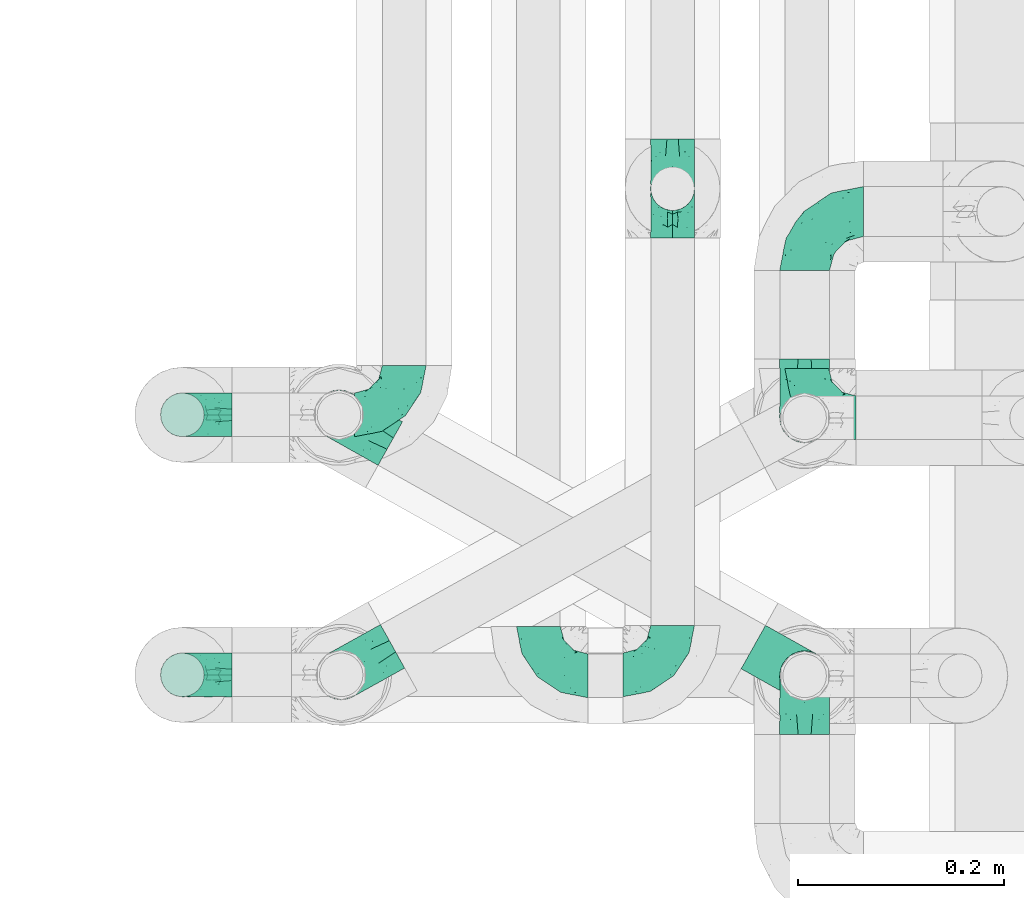
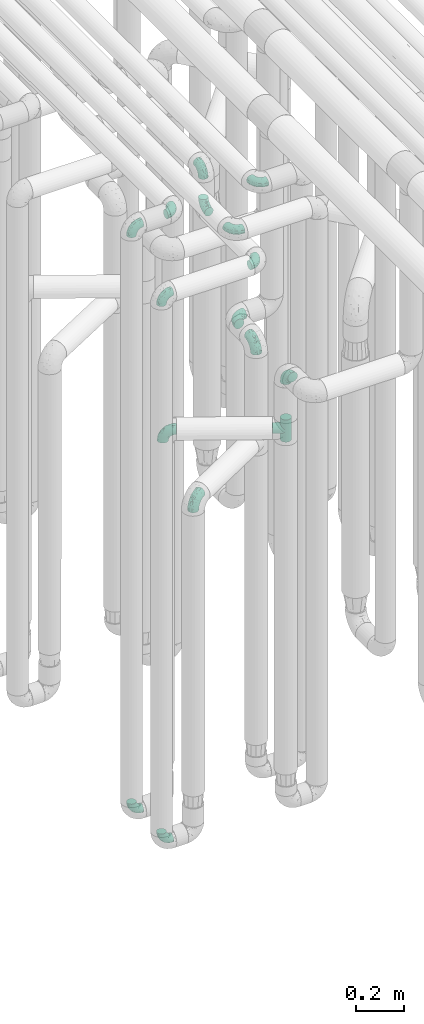
# One storey, part 598 of 824: 16 flow fittings.
"""IFC2X3 building model written with IfcOpenShell, lengths in millimetres."""

from ifc_helpers import new_model, entity, si_unit, converted_unit, derived_unit, direction, frame, origin, place, context, subcontext, project, spatial, faceted_brep, source, transform, mapped, material, type_object, type_shapes, element, save


model = new_model("IFC2X3")

# Units and contexts
model_context = context("Model", 3, precision=0.01, world=origin(), true_north=direction((6.12303176911189e-17, 1.0)))
body_context = subcontext(model_context, "Body", "Model", "MODEL_VIEW")
ifc_project = project(units=[si_unit("LENGTHUNIT", "METRE", prefix="MILLI"), si_unit("AREAUNIT", "SQUARE_METRE"), si_unit("VOLUMEUNIT", "CUBIC_METRE"), converted_unit("PLANEANGLEUNIT", "DEGREE", entity("IfcRatioMeasure", 0.0174532925199433), si_unit("PLANEANGLEUNIT", "RADIAN"), dimensions=[0, 0, 0, 0, 0, 0, 0]), si_unit("MASSUNIT", "GRAM", prefix="KILO"), derived_unit("MASSDENSITYUNIT", [(si_unit("MASSUNIT", "GRAM", prefix="KILO"), 1), (si_unit("LENGTHUNIT", "METRE"), -3)]), derived_unit("MOMENTOFINERTIAUNIT", [(si_unit("LENGTHUNIT", "METRE"), 4)]), si_unit("TIMEUNIT", "SECOND"), si_unit("FREQUENCYUNIT", "HERTZ"), si_unit("THERMODYNAMICTEMPERATUREUNIT", "DEGREE_CELSIUS"), derived_unit("THERMALTRANSMITTANCEUNIT", [(si_unit("MASSUNIT", "GRAM", prefix="KILO"), 1), (si_unit("THERMODYNAMICTEMPERATUREUNIT", "KELVIN"), -1), (si_unit("TIMEUNIT", "SECOND"), -3)]), derived_unit("VOLUMETRICFLOWRATEUNIT", [(si_unit("LENGTHUNIT", "METRE"), 3), (si_unit("TIMEUNIT", "SECOND"), -1)]), derived_unit("MASSFLOWRATEUNIT", [(si_unit("MASSUNIT", "GRAM", prefix="KILO"), 1), (si_unit("TIMEUNIT", "SECOND"), -1)]), derived_unit("ROTATIONALFREQUENCYUNIT", [(si_unit("TIMEUNIT", "SECOND"), -1)]), si_unit("ELECTRICCURRENTUNIT", "AMPERE"), si_unit("ELECTRICVOLTAGEUNIT", "VOLT"), si_unit("POWERUNIT", "WATT"), si_unit("FORCEUNIT", "NEWTON", prefix="KILO"), si_unit("ILLUMINANCEUNIT", "LUX"), si_unit("LUMINOUSFLUXUNIT", "LUMEN"), si_unit("LUMINOUSINTENSITYUNIT", "CANDELA"), derived_unit("USERDEFINED", [(si_unit("MASSUNIT", "GRAM", prefix="KILO"), -1), (si_unit("LENGTHUNIT", "METRE"), -2), (si_unit("TIMEUNIT", "SECOND"), 3), (si_unit("LUMINOUSFLUXUNIT", "LUMEN"), 1)]), derived_unit("LINEARVELOCITYUNIT", [(si_unit("LENGTHUNIT", "METRE"), 1), (si_unit("TIMEUNIT", "SECOND"), -1)]), si_unit("PRESSUREUNIT", "PASCAL"), derived_unit("USERDEFINED", [(si_unit("LENGTHUNIT", "METRE"), -2), (si_unit("MASSUNIT", "GRAM", prefix="KILO"), 1), (si_unit("TIMEUNIT", "SECOND"), -2)]), derived_unit("LINEARFORCEUNIT", [(si_unit("MASSUNIT", "GRAM", prefix="KILO"), 1), (si_unit("LENGTHUNIT", "METRE"), 1), (si_unit("TIMEUNIT", "SECOND"), -2), (si_unit("LENGTHUNIT", "METRE"), -1)]), derived_unit("PLANARFORCEUNIT", [(si_unit("MASSUNIT", "GRAM", prefix="KILO"), 1), (si_unit("LENGTHUNIT", "METRE"), 1), (si_unit("TIMEUNIT", "SECOND"), -2), (si_unit("LENGTHUNIT", "METRE"), -2)])], contexts=[model_context])

# Site, building, storey
site_placement = place(None, origin())
site = spatial("IfcSite", under=ifc_project, at=site_placement, CompositionType="ELEMENT")
building_placement = place(site_placement, origin())
building = spatial("IfcBuilding", under=site, at=building_placement, CompositionType="ELEMENT")
storey_placement = place(building_placement, frame((0.0, 0.0, 28200.0)))
storey = spatial("IfcBuildingStorey", under=building, at=storey_placement, CompositionType="ELEMENT", Elevation=28200.0)

# Flow fittings
ifc_material = material()
pipe_fitting_type_1 = type_object("IfcPipeFittingType", PredefinedType="NOTDEFINED", material=ifc_material)
shared_shape_1 = source(origin(), body_context, "Body", "Brep", [
    faceted_brep([(-57.0, 12.07, -20.91), (-57.0, 6.25, -23.33), (-57.0, 0.0, -24.15), (-57.0, -6.25, -23.33), (-57.0, -12.08, -20.91), (-57.0, -17.08, -17.08), (-57.0, -20.91, -12.08), (-57.0, -23.33, -6.25), (-57.0, -24.15, 0.0), (-57.0, -23.33, 6.25), (-57.0, -20.91, 12.07), (-57.0, -17.08, 17.08), (-57.0, -12.08, 20.91), (-57.0, -6.25, 23.33), (-57.0, 0.0, 24.15), (-57.0, 6.25, 23.33), (-57.0, 12.07, 20.91), (-57.0, 17.08, 17.08), (-57.0, 20.91, 12.07), (-57.0, 23.33, 6.25), (-57.0, 24.15, 0.0), (-57.0, 23.33, -6.25), (-57.0, 20.91, -12.08), (-57.0, 17.08, -17.08), (0.0, 57.0, -24.15), (-6.25, 57.0, -23.33), (-12.07, 57.0, -20.91), (-17.08, 57.0, -17.08), (-20.91, 57.0, -12.08), (-23.33, 57.0, -6.25), (-24.15, 57.0, 0.0), (-23.33, 57.0, 6.25), (-20.91, 57.0, 12.07), (-17.08, 57.0, 17.08), (-12.07, 57.0, 20.91), (-6.25, 57.0, 23.33), (0.0, 57.0, 24.15), (6.25, 57.0, 23.33), (12.08, 57.0, 20.91), (17.08, 57.0, 17.08), (20.91, 57.0, 12.07), (23.33, 57.0, 6.25), (24.15, 57.0, 0.0), (23.33, 57.0, -6.25), (20.91, 57.0, -12.08), (17.08, 57.0, -17.08), (12.08, 57.0, -20.91), (6.25, 57.0, -23.33), (14.9, 21.14, 6.17), (13.61, 24.64, 12.48), (6.23, 8.95, 8.98), (-41.47, -21.06, 0.0), (-41.92, -18.38, 13.72), (-24.64, -13.61, 12.48), (-37.37, -13.24, 18.15), (-6.8, -4.93, 8.18), (-21.76, -15.19, 6.22), (-12.78, -9.18, 0.0), (-37.73, -20.51, 7.75), (-7.38, 7.38, 20.24), (-23.37, -4.26, 20.42), (-11.9, -3.19, 15.86), (-42.14, -8.7, 21.82), (13.24, 37.37, 18.15), (9.33, 23.53, 16.85), (4.26, 23.37, 20.42), (2.77, 10.92, 15.55), (-29.46, 0.91, 23.52), (-44.13, 20.56, 15.69), (-39.25, 26.33, 10.88), (-49.02, 22.92, 9.96), (-34.58, 23.87, 17.15), (-15.8, 6.8, 22.81), (-8.67, 20.47, 23.88), (-18.12, 12.9, 24.08), (-48.29, 14.92, 19.65), (-44.06, -2.85, 23.78), (-9.23, 48.95, 22.58), (-3.78, 42.74, 24.07), (-40.34, 4.26, 24.09), (-44.02, 26.14, 5.46), (-44.04, 9.88, 22.74), (-4.95, 16.87, 22.52), (-2.75, 1.43, 12.5), (-25.48, 40.98, 10.71), (20.51, 37.73, 7.75), (18.38, 41.92, 13.72), (8.7, 42.14, 21.82), (-25.95, -17.97, 0.0), (2.85, 44.06, 23.78), (21.06, 41.47, 0.0), (17.97, 25.95, 0.0), (-24.04, -9.27, 17.13), (-33.26, 33.26, 5.86), (-28.55, 40.57, 0.0), (-40.57, 28.55, 0.0), (-25.29, 47.19, 4.06), (-27.01, 31.1, 16.77), (-15.7, 43.95, 19.9), (-20.27, 45.22, 15.61), (-30.53, 31.98, 12.64), (-11.28, 38.33, 22.92), (-9.97, 27.88, 24.09), (-20.15, 30.26, 21.25), (-31.25, 11.75, 23.64), (-28.75, 7.23, 24.15), (-29.53, 18.06, 22.27), (-28.44, 24.21, 20.02), (-37.55, 17.7, 20.26), (-15.88, 29.25, 22.99), (-20.82, 20.82, 23.44), (-0.91, 29.46, 23.52), (-13.5, -7.67, 12.04), (1.49, 1.56, 5.16), (8.86, 10.35, 4.59), (0.38, -0.38, 0.0), (9.18, 12.78, 0.0), (-37.37, -13.24, -18.15), (8.86, 10.35, -4.59), (-45.22, 20.27, -15.61), (-43.95, 15.7, -19.9), (-38.33, 11.28, -22.92), (-48.95, 9.23, -22.58), (-47.19, 25.29, -4.06), (-33.26, 33.26, -5.86), (18.38, 41.92, -13.72), (-30.26, 20.15, -21.25), (2.85, 44.06, -23.78), (-4.26, 40.34, -24.09), (-40.98, 25.48, -10.71), (-41.92, -18.38, -13.72), (9.25, 23.5, -16.92), (4.26, 23.37, -20.42), (13.24, 37.37, -18.15), (-37.73, -20.51, -7.75), (-11.75, 31.25, -23.64), (-7.23, 28.75, -24.15), (-12.9, 18.12, -24.08), (8.7, 42.14, -21.82), (-44.06, -2.85, -23.78), (-6.8, 15.8, -22.81), (-20.47, 8.67, -23.88), (-24.64, -13.61, -12.48), (-42.74, 3.78, -24.07), (-18.06, 29.53, -22.27), (-24.21, 28.44, -20.02), (-27.88, 9.97, -24.09), (-31.1, 27.01, -16.77), (-26.14, 44.02, -5.46), (14.9, 21.14, -6.17), (20.51, 37.73, -7.75), (-9.88, 44.04, -22.74), (-20.56, 44.13, -15.69), (-21.76, -15.19, -6.22), (-13.5, -7.67, -12.04), (-24.14, -9.76, -16.74), (-11.9, -3.19, -15.86), (-14.92, 48.29, -19.65), (-23.37, -4.26, -20.42), (-0.91, 29.46, -23.52), (-26.33, 39.25, -10.88), (-23.87, 34.58, -17.15), (-42.14, -8.7, -21.82), (-22.92, 49.02, -9.96), (13.61, 24.64, -12.48), (-31.98, 30.53, -12.64), (-16.87, 4.95, -22.52), (-17.7, 37.55, -20.26), (-29.25, 15.88, -22.99), (-20.82, 20.82, -23.44), (-29.46, 0.91, -23.52), (-7.38, 7.38, -20.24), (2.77, 10.92, -15.55), (6.23, 8.95, -8.98), (-6.8, -4.93, -8.18), (-2.81, 1.41, -12.54), (1.49, 1.56, -5.16)], [[[0, 1, 2, 3, 4, 5, 6, 7, 8, 9, 10, 11, 12, 13, 14, 15, 16, 17, 18, 19, 20, 21, 22, 23]], [[24, 25, 26, 27, 28, 29, 30, 31, 32, 33, 34, 35, 36, 37, 38, 39, 40, 41, 42, 43, 44, 45, 46, 47]], [[48, 49, 50]], [[9, 8, 51]], [[52, 53, 54]], [[55, 56, 57]], [[10, 58, 52]], [[9, 58, 10]], [[59, 60, 61]], [[54, 12, 11]], [[54, 62, 12]], [[63, 39, 38]], [[64, 65, 66]], [[62, 60, 67]], [[68, 69, 70]], [[71, 69, 68]], [[72, 73, 74]], [[16, 75, 17]], [[13, 76, 14]], [[35, 77, 78]], [[14, 79, 15]], [[17, 68, 18]], [[14, 76, 79]], [[20, 19, 80]], [[70, 19, 18]], [[81, 15, 79]], [[15, 81, 16]], [[73, 72, 82]], [[66, 83, 50]], [[32, 31, 84]], [[85, 86, 49]], [[63, 87, 65]], [[56, 58, 88]], [[36, 89, 37]], [[85, 41, 40]], [[36, 35, 78]], [[90, 41, 85]], [[40, 39, 86]], [[12, 62, 13]], [[86, 85, 40]], [[48, 85, 49]], [[85, 91, 90]], [[87, 38, 37]], [[92, 60, 54]], [[80, 69, 93]], [[93, 94, 95]], [[10, 52, 11]], [[94, 96, 30]], [[97, 98, 99]], [[80, 93, 95]], [[100, 97, 84]], [[99, 98, 33]], [[101, 102, 78]], [[103, 101, 98]], [[96, 31, 30]], [[77, 98, 101]], [[77, 35, 34]], [[34, 33, 98]], [[9, 51, 58]], [[87, 63, 38]], [[104, 105, 74]], [[106, 103, 107]], [[106, 81, 104]], [[75, 68, 17]], [[108, 107, 71]], [[33, 32, 99]], [[109, 103, 110]], [[101, 109, 102]], [[89, 78, 111]], [[53, 52, 58]], [[54, 11, 52]], [[60, 62, 54]], [[88, 58, 51]], [[76, 62, 67]], [[53, 112, 92]], [[60, 59, 72]], [[39, 63, 86]], [[49, 86, 63]], [[89, 87, 37]], [[42, 41, 90]], [[111, 82, 65]], [[111, 65, 87]], [[65, 59, 66]], [[104, 81, 79]], [[75, 81, 108]], [[32, 84, 99]], [[97, 99, 84]], [[98, 97, 103]], [[106, 107, 108]], [[74, 102, 110]], [[111, 78, 102]], [[74, 110, 104]], [[74, 67, 72]], [[61, 92, 112]], [[66, 59, 61]], [[56, 53, 58]], [[66, 50, 49]], [[61, 112, 83]], [[66, 49, 64]], [[78, 89, 36]], [[87, 89, 111]], [[62, 76, 13]], [[79, 76, 67]], [[100, 93, 69]], [[96, 93, 84]], [[55, 113, 50]], [[113, 114, 50]], [[104, 79, 105]], [[106, 104, 110]], [[20, 80, 95]], [[85, 48, 91]], [[115, 114, 113]], [[116, 91, 48]], [[70, 80, 19]], [[93, 96, 94]], [[84, 31, 96]], [[103, 106, 110]], [[81, 106, 108]], [[103, 97, 107]], [[71, 107, 97]], [[71, 97, 100]], [[108, 71, 68]], [[79, 67, 105]], [[67, 74, 105]], [[115, 113, 57]], [[112, 56, 55]], [[56, 88, 57]], [[60, 72, 67]], [[82, 72, 59]], [[65, 82, 59]], [[82, 111, 73]], [[111, 102, 73]], [[102, 74, 73]], [[81, 75, 16]], [[68, 75, 108]], [[68, 70, 18]], [[80, 70, 69]], [[98, 77, 34]], [[78, 77, 101]], [[93, 100, 84]], [[71, 100, 69]], [[102, 109, 110]], [[101, 103, 109]], [[53, 92, 54]], [[61, 60, 92]], [[56, 112, 53]], [[83, 112, 55]], [[50, 83, 55]], [[61, 83, 66]], [[49, 63, 64]], [[65, 64, 63]], [[57, 113, 55]], [[114, 115, 116]], [[116, 48, 114]], [[48, 50, 114]], [[117, 5, 4]], [[116, 115, 118]], [[119, 120, 23]], [[121, 122, 120]], [[95, 123, 20]], [[0, 23, 120]], [[124, 95, 94]], [[125, 45, 44]], [[121, 120, 126]], [[24, 127, 128]], [[22, 21, 129]], [[0, 122, 1]], [[5, 117, 130]], [[131, 132, 133]], [[134, 88, 51]], [[135, 136, 137]], [[6, 5, 130]], [[46, 138, 47]], [[139, 3, 2]], [[140, 141, 137]], [[6, 134, 7]], [[134, 130, 142]], [[143, 2, 1]], [[144, 126, 145]], [[121, 146, 143]], [[147, 120, 119]], [[94, 148, 124]], [[149, 150, 91]], [[30, 29, 148]], [[151, 25, 128]], [[27, 152, 28]], [[134, 153, 88]], [[154, 155, 156]], [[27, 26, 157]], [[151, 26, 25]], [[155, 158, 156]], [[24, 47, 127]], [[1, 122, 143]], [[138, 132, 159]], [[160, 152, 161]], [[24, 128, 25]], [[46, 133, 138]], [[162, 117, 4]], [[148, 160, 124]], [[152, 160, 163]], [[154, 142, 155]], [[45, 125, 133]], [[133, 46, 45]], [[125, 164, 133]], [[51, 7, 134]], [[42, 90, 43]], [[165, 147, 129]], [[153, 134, 142]], [[43, 150, 44]], [[162, 4, 3]], [[141, 140, 166]], [[117, 162, 158]], [[163, 29, 28]], [[43, 90, 150]], [[123, 21, 20]], [[144, 151, 135]], [[157, 152, 27]], [[167, 145, 161]], [[23, 22, 119]], [[168, 126, 169]], [[121, 168, 146]], [[139, 143, 170]], [[142, 130, 117]], [[8, 7, 51]], [[134, 6, 130]], [[139, 162, 3]], [[170, 166, 158]], [[170, 158, 162]], [[158, 171, 156]], [[44, 150, 125]], [[91, 150, 90]], [[164, 125, 150]], [[132, 138, 133]], [[127, 138, 159]], [[131, 164, 172]], [[132, 171, 140]], [[135, 151, 128]], [[157, 151, 167]], [[22, 129, 119]], [[147, 119, 129]], [[120, 147, 126]], [[144, 145, 167]], [[137, 146, 169]], [[170, 143, 146]], [[137, 169, 135]], [[137, 159, 140]], [[171, 172, 156]], [[173, 174, 175]], [[156, 175, 154]], [[174, 57, 153]], [[132, 172, 171]], [[172, 164, 173]], [[143, 139, 2]], [[162, 139, 170]], [[138, 127, 47]], [[128, 127, 159]], [[165, 124, 160]], [[123, 124, 129]], [[149, 173, 164]], [[176, 174, 173]], [[135, 128, 136]], [[144, 135, 169]], [[150, 149, 164]], [[176, 118, 115]], [[149, 91, 116]], [[30, 148, 94]], [[163, 148, 29]], [[124, 123, 95]], [[129, 21, 123]], [[126, 144, 169]], [[151, 144, 167]], [[126, 147, 145]], [[161, 145, 147]], [[161, 147, 165]], [[167, 161, 152]], [[128, 159, 136]], [[159, 137, 136]], [[154, 153, 142]], [[132, 140, 159]], [[174, 176, 57]], [[57, 88, 153]], [[166, 140, 171]], [[158, 166, 171]], [[166, 170, 141]], [[170, 146, 141]], [[146, 137, 141]], [[151, 157, 26]], [[152, 157, 167]], [[152, 163, 28]], [[148, 163, 160]], [[120, 122, 0]], [[143, 122, 121]], [[124, 165, 129]], [[161, 165, 160]], [[146, 168, 169]], [[121, 126, 168]], [[142, 117, 155]], [[158, 155, 117]], [[175, 156, 172]], [[153, 154, 174]], [[173, 175, 172]], [[174, 154, 175]], [[164, 131, 133]], [[172, 132, 131]], [[176, 173, 118]], [[57, 176, 115]], [[173, 149, 118]], [[149, 116, 118]]]),
])
type_shapes(pipe_fitting_type_1, [shared_shape_1])
for number, where, z_axis, x_axis in (
    (1, (35728.05, 10606.2, 2600.0), (-1.0, 0.0, 0.0), (0.0, 0.0, 1.0)),
    (2, (35728.05, 10806.2, 2600.0), (0.0, 0.0, 1.0), (-1.0, 0.0, 0.0)),
    (3, (35728.05, 10356.17, 2600.0), (1.0, 0.0, 0.0), (0.0, 0.0, 1.0)),
    (4, (35278.87, 10357.09, 2100.0), (0.486104408033655, -0.873900740639491, 0.0), (-0.873900740639491, -0.486104408033655, 0.0)),
    (5, (35276.74, 10609.13, 2305.0), (-0.4889196285334, -0.872328835264983, 0.0), (-0.872328835264983, 0.4889196285334, 0.0)),
):
    element("IfcFlowFitting", number, at=place(storey_placement, frame(where, z_axis=z_axis, x_axis=x_axis)), inside=storey, type_object=pipe_fitting_type_1, material=ifc_material, context=body_context, shape_type="MappedRepresentation", body=[
        mapped(shared_shape_1, transform((0.0, 0.0, 0.0), scale=1.0)),
    ])
pipe_fitting_type_2 = type_object("IfcPipeFittingType", PredefinedType="NOTDEFINED", material=ifc_material)
shared_shape_2 = source(origin(), body_context, "Body", "Brep", [
    faceted_brep([(-48.0, 10.6, -18.36), (-48.0, 5.49, -20.48), (-48.0, 0.0, -21.2), (-48.0, -5.49, -20.48), (-48.0, -10.6, -18.36), (-48.0, -14.99, -14.99), (-48.0, -18.36, -10.6), (-48.0, -20.48, -5.49), (-48.0, -21.2, 0.0), (-48.0, -20.48, 5.49), (-48.0, -18.36, 10.6), (-48.0, -14.99, 14.99), (-48.0, -10.6, 18.36), (-48.0, -5.49, 20.48), (-48.0, 0.0, 21.2), (-48.0, 5.49, 20.48), (-48.0, 10.6, 18.36), (-48.0, 14.99, 14.99), (-48.0, 18.36, 10.6), (-48.0, 20.48, 5.49), (-48.0, 21.2, 0.0), (-48.0, 20.48, -5.49), (-48.0, 18.36, -10.6), (-48.0, 14.99, -14.99), (0.0, 48.0, -21.2), (-5.49, 48.0, -20.48), (-10.6, 48.0, -18.36), (-14.99, 48.0, -14.99), (-18.36, 48.0, -10.6), (-20.48, 48.0, -5.49), (-21.2, 48.0, 0.0), (-20.48, 48.0, 5.49), (-18.36, 48.0, 10.6), (-14.99, 48.0, 14.99), (-10.6, 48.0, 18.36), (-5.49, 48.0, 20.48), (0.0, 48.0, 21.2), (5.49, 48.0, 20.48), (10.6, 48.0, 18.36), (14.99, 48.0, 14.99), (18.36, 48.0, 10.6), (20.48, 48.0, 5.49), (21.2, 48.0, 0.0), (20.48, 48.0, -5.49), (18.36, 48.0, -10.6), (14.99, 48.0, -14.99), (10.6, 48.0, -18.36), (5.49, 48.0, -20.48), (-35.25, -16.22, 12.01), (-34.76, -18.57, 0.0), (-20.87, -12.37, 10.9), (-31.49, -11.78, 15.9), (-37.0, -2.58, 20.86), (-33.89, 3.62, 21.15), (-31.81, -18.14, 6.76), (-5.78, 5.78, 17.67), (-19.42, -4.1, 17.86), (-9.6, -3.39, 13.73), (-35.44, -7.73, 19.13), (11.78, 31.49, 15.9), (-5.93, -5.46, 6.95), (-18.45, -13.78, 5.46), (-10.29, -8.43, 0.0), (-24.6, 0.55, 20.62), (-37.28, 17.94, 13.81), (-33.38, 22.85, 9.59), (-41.46, 20.06, 8.75), (-29.51, 20.45, 15.16), (-15.04, 10.79, 21.13), (-7.08, 16.98, 20.93), (-8.39, 23.51, 21.15), (-40.86, 13.03, 17.26), (-8.05, 41.26, 19.83), (-3.21, 35.97, 21.14), (8.53, 19.66, 14.74), (4.1, 19.42, 17.86), (-37.72, 22.66, 4.78), (-37.07, 8.58, 19.98), (-13.0, 5.43, 19.97), (-3.78, 13.93, 19.7), (3.02, 8.69, 13.43), (-2.27, -0.05, 10.65), (6.22, 6.99, 7.09), (-22.25, 34.6, 9.45), (18.14, 31.81, 6.76), (16.22, 35.25, 12.01), (12.37, 20.87, 10.9), (7.73, 35.44, 19.13), (-21.52, -15.93, 0.0), (2.58, 37.0, 20.86), (18.57, 34.76, 0.0), (13.78, 18.45, 5.46), (15.93, 21.52, 0.0), (-20.03, -8.54, 14.9), (-28.6, 28.6, 5.16), (-24.79, 34.6, 0.0), (-34.6, 24.79, 0.0), (-22.81, 37.41, 4.68), (-23.36, 26.33, 14.79), (-13.68, 37.05, 17.49), (-17.72, 38.12, 13.73), (-26.25, 27.3, 11.24), (-9.71, 32.34, 20.14), (-17.26, 25.6, 18.71), (-26.33, 9.99, 20.77), (-24.06, 6.05, 21.2), (-25.02, 15.46, 19.56), (-24.3, 20.72, 17.57), (-31.95, 15.23, 17.8), (-13.53, 24.7, 20.21), (-17.6, 17.6, 20.6), (-0.55, 24.6, 20.62), (-11.41, -7.48, 10.43), (0.93, -0.93, 0.0), (8.43, 10.29, 0.0), (-11.41, -7.48, -10.43), (-20.1, -8.84, -14.66), (-9.6, -3.39, -13.73), (7.73, 35.44, -19.13), (4.1, 19.42, -17.86), (-0.55, 24.6, -20.62), (-38.12, 17.72, -13.73), (-37.05, 13.68, -17.49), (-32.34, 9.71, -20.14), (-41.26, 8.05, -19.83), (-37.41, 22.81, -4.68), (-23.51, 8.39, -21.15), (-35.97, 3.21, -21.14), (-28.6, 28.6, -5.16), (-31.81, -18.14, -6.76), (-18.45, -13.78, -5.46), (-25.6, 17.26, -18.71), (-19.42, -4.1, -17.86), (-17.94, 37.28, -13.81), (-22.85, 33.38, -9.59), (-20.06, 41.46, -8.75), (-31.49, -11.78, -15.9), (-35.25, -16.22, -12.01), (8.53, 19.66, -14.74), (11.78, 31.49, -15.9), (-9.99, 26.33, -20.77), (-6.05, 24.06, -21.2), (-10.79, 15.04, -21.13), (-37.0, -2.58, -20.86), (-16.98, 7.08, -20.93), (-5.43, 13.0, -19.97), (-13.93, 3.78, -19.7), (-20.87, -12.37, -10.9), (-26.33, 23.36, -14.79), (-22.66, 37.72, -4.78), (13.78, 18.45, -5.46), (18.14, 31.81, -6.76), (-15.46, 25.02, -19.56), (-20.72, 24.3, -17.57), (16.22, 35.25, -12.01), (-13.03, 40.86, -17.26), (-8.58, 37.07, -19.98), (2.58, 37.0, -20.86), (-3.62, 33.89, -21.15), (-34.6, 22.25, -9.45), (6.22, 6.99, -7.09), (-20.45, 29.51, -15.16), (-35.44, -7.73, -19.13), (12.37, 20.87, -10.9), (-27.3, 26.25, -11.24), (-15.23, 31.95, -17.8), (-24.7, 13.53, -20.21), (-24.6, 0.55, -20.62), (-5.78, 5.78, -17.67), (-17.6, 17.6, -20.6), (3.02, 8.69, -13.43), (-5.93, -5.46, -6.95), (-2.27, -0.05, -10.65)], [[[0, 1, 2, 3, 4, 5, 6, 7, 8, 9, 10, 11, 12, 13, 14, 15, 16, 17, 18, 19, 20, 21, 22, 23]], [[24, 25, 26, 27, 28, 29, 30, 31, 32, 33, 34, 35, 36, 37, 38, 39, 40, 41, 42, 43, 44, 45, 46, 47]], [[10, 48, 11]], [[9, 8, 49]], [[48, 50, 51]], [[14, 52, 53]], [[10, 54, 48]], [[9, 54, 10]], [[55, 56, 57]], [[51, 12, 11]], [[51, 58, 12]], [[59, 39, 38]], [[60, 61, 62]], [[58, 56, 63]], [[64, 65, 66]], [[67, 65, 64]], [[68, 69, 70]], [[16, 71, 17]], [[13, 52, 14]], [[35, 72, 73]], [[14, 53, 15]], [[17, 64, 18]], [[74, 59, 75]], [[20, 19, 76]], [[66, 19, 18]], [[77, 15, 53]], [[15, 77, 16]], [[69, 78, 79]], [[80, 81, 82]], [[32, 31, 83]], [[84, 85, 86]], [[59, 87, 75]], [[61, 54, 88]], [[36, 89, 37]], [[84, 41, 40]], [[36, 35, 73]], [[90, 41, 84]], [[40, 39, 85]], [[12, 58, 13]], [[85, 84, 40]], [[91, 84, 86]], [[84, 92, 90]], [[87, 38, 37]], [[93, 56, 51]], [[65, 94, 76]], [[94, 95, 96]], [[84, 91, 92]], [[95, 97, 30]], [[98, 99, 100]], [[76, 94, 96]], [[101, 98, 83]], [[100, 99, 33]], [[102, 70, 73]], [[103, 102, 99]], [[94, 97, 95]], [[72, 99, 102]], [[72, 35, 34]], [[34, 33, 99]], [[9, 49, 54]], [[87, 59, 38]], [[104, 105, 68]], [[106, 103, 107]], [[106, 77, 104]], [[71, 64, 17]], [[108, 107, 67]], [[33, 32, 100]], [[109, 103, 110]], [[102, 109, 70]], [[89, 73, 111]], [[50, 48, 54]], [[51, 11, 48]], [[56, 58, 51]], [[88, 54, 49]], [[52, 58, 63]], [[50, 112, 93]], [[56, 55, 78]], [[39, 59, 85]], [[86, 85, 59]], [[89, 87, 37]], [[42, 41, 90]], [[111, 79, 75]], [[111, 75, 87]], [[75, 55, 80]], [[104, 77, 53]], [[71, 77, 108]], [[32, 83, 100]], [[98, 100, 83]], [[99, 98, 103]], [[106, 107, 108]], [[68, 70, 110]], [[111, 73, 70]], [[68, 110, 104]], [[68, 63, 78]], [[57, 93, 112]], [[80, 55, 57]], [[61, 50, 54]], [[80, 82, 86]], [[81, 57, 112]], [[74, 86, 59]], [[60, 113, 82]], [[82, 114, 91]], [[101, 94, 65]], [[97, 94, 83]], [[73, 89, 36]], [[87, 89, 111]], [[58, 52, 13]], [[53, 52, 63]], [[104, 53, 105]], [[106, 104, 110]], [[20, 76, 96]], [[76, 19, 66]], [[103, 106, 110]], [[77, 106, 108]], [[103, 98, 107]], [[67, 107, 98]], [[67, 98, 101]], [[108, 67, 64]], [[53, 63, 105]], [[63, 68, 105]], [[83, 31, 97]], [[30, 97, 31]], [[62, 113, 60]], [[112, 61, 60]], [[61, 88, 62]], [[86, 82, 91]], [[56, 78, 63]], [[114, 82, 113]], [[114, 92, 91]], [[79, 78, 55]], [[75, 79, 55]], [[69, 79, 111]], [[70, 69, 111]], [[78, 69, 68]], [[77, 71, 16]], [[64, 71, 108]], [[64, 66, 18]], [[76, 66, 65]], [[99, 72, 34]], [[73, 72, 102]], [[94, 101, 83]], [[67, 101, 65]], [[75, 80, 74]], [[80, 86, 74]], [[70, 109, 110]], [[102, 103, 109]], [[50, 93, 51]], [[57, 56, 93]], [[61, 112, 50]], [[81, 112, 60]], [[82, 81, 60]], [[80, 57, 81]], [[115, 116, 117]], [[118, 119, 120]], [[121, 122, 23]], [[123, 124, 122]], [[96, 125, 20]], [[123, 126, 127]], [[128, 96, 95]], [[129, 130, 88]], [[123, 122, 131]], [[116, 132, 117]], [[133, 134, 135]], [[0, 124, 1]], [[5, 136, 137]], [[138, 119, 139]], [[129, 88, 49]], [[140, 141, 142]], [[6, 5, 137]], [[46, 118, 47]], [[143, 3, 2]], [[144, 145, 146]], [[6, 129, 7]], [[129, 137, 147]], [[127, 2, 1]], [[148, 122, 121]], [[128, 125, 96]], [[134, 128, 149]], [[95, 149, 128]], [[150, 151, 92]], [[30, 29, 149]], [[152, 131, 153]], [[27, 133, 28]], [[154, 45, 44]], [[136, 5, 4]], [[27, 26, 155]], [[156, 26, 25]], [[24, 157, 158]], [[24, 47, 157]], [[22, 21, 159]], [[160, 150, 114]], [[134, 133, 161]], [[142, 144, 126]], [[46, 139, 118]], [[162, 136, 4]], [[156, 25, 158]], [[1, 124, 127]], [[115, 147, 116]], [[45, 154, 139]], [[139, 46, 45]], [[154, 163, 139]], [[162, 4, 3]], [[42, 90, 43]], [[130, 129, 147]], [[49, 7, 129]], [[43, 151, 44]], [[0, 23, 122]], [[24, 158, 25]], [[136, 162, 132]], [[135, 29, 28]], [[43, 90, 151]], [[164, 148, 159]], [[152, 156, 140]], [[155, 133, 27]], [[165, 153, 161]], [[23, 22, 121]], [[123, 131, 166]], [[123, 166, 126]], [[143, 127, 167]], [[147, 137, 136]], [[8, 7, 49]], [[129, 6, 137]], [[143, 162, 3]], [[167, 146, 132]], [[167, 132, 162]], [[132, 168, 117]], [[44, 151, 154]], [[92, 151, 90]], [[163, 154, 151]], [[119, 118, 139]], [[157, 118, 120]], [[138, 139, 163]], [[119, 168, 145]], [[140, 156, 158]], [[155, 156, 165]], [[22, 159, 121]], [[148, 121, 159]], [[122, 148, 131]], [[152, 153, 165]], [[142, 126, 169]], [[167, 127, 126]], [[142, 169, 140]], [[142, 120, 145]], [[168, 170, 117]], [[160, 171, 172]], [[115, 172, 171]], [[171, 62, 130]], [[119, 170, 168]], [[170, 163, 160]], [[150, 163, 151]], [[113, 171, 160]], [[164, 128, 134]], [[125, 128, 159]], [[127, 143, 2]], [[162, 143, 167]], [[118, 157, 47]], [[158, 157, 120]], [[140, 158, 141]], [[152, 140, 169]], [[30, 149, 95]], [[149, 29, 135]], [[131, 152, 169]], [[156, 152, 165]], [[131, 148, 153]], [[161, 153, 148]], [[161, 148, 164]], [[165, 161, 133]], [[158, 120, 141]], [[120, 142, 141]], [[159, 21, 125]], [[20, 125, 21]], [[115, 130, 147]], [[114, 113, 160]], [[62, 171, 113]], [[62, 88, 130]], [[160, 163, 150]], [[150, 92, 114]], [[119, 145, 120]], [[146, 145, 168]], [[132, 146, 168]], [[144, 146, 167]], [[126, 144, 167]], [[145, 144, 142]], [[156, 155, 26]], [[133, 155, 165]], [[133, 135, 28]], [[149, 135, 134]], [[122, 124, 0]], [[127, 124, 123]], [[128, 164, 159]], [[161, 164, 134]], [[163, 170, 138]], [[170, 119, 138]], [[131, 169, 166]], [[126, 166, 169]], [[147, 136, 116]], [[132, 116, 136]], [[172, 115, 117]], [[130, 115, 171]], [[117, 170, 172]], [[160, 172, 170]]]),
])
type_shapes(pipe_fitting_type_2, [shared_shape_2])
for number, where, z_axis, x_axis in (
    (6, (35125.03, 10609.14, 400.0), (0.0, 1.0, 0.0), (-1.0, 0.0, 0.0)),
    (7, (35125.03, 10609.14, 3400.0), (0.0, 1.0, 0.0), (0.0, 0.0, 1.0)),
):
    element("IfcFlowFitting", number, at=place(storey_placement, frame(where, z_axis=z_axis, x_axis=x_axis)), inside=storey, type_object=pipe_fitting_type_2, material=ifc_material, context=body_context, shape_type="MappedRepresentation", body=[
        mapped(shared_shape_2, transform((0.0, 0.0, 0.0), scale=1.0)),
    ])
flow_fitting_1_placement = place(storey_placement, frame((35340.03, 10609.14, 3400.0)))
element("IfcFlowFitting", 8, at=flow_fitting_1_placement, inside=storey, type_object=pipe_fitting_type_2, material=ifc_material, context=body_context, shape_type="MappedRepresentation", body=[
    mapped(shared_shape_2, transform((0.0, 0.0, 0.0), scale=1.0)),
])
for number, where, z_axis, x_axis in (
    (9, (35125.03, 10357.08, 400.0), (0.0, 1.0, 0.0), (-1.0, 0.0, 0.0)),
    (10, (35125.03, 10357.08, 3200.0), (0.0, 1.0, 0.0), (0.0, 0.0, 1.0)),
    (11, (35600.09, 10828.38, 3400.0), (1.0, 0.0, 0.0), (0.0, -1.0, 0.0)),
):
    element("IfcFlowFitting", number, at=place(storey_placement, frame(where, z_axis=z_axis, x_axis=x_axis)), inside=storey, type_object=pipe_fitting_type_2, material=ifc_material, context=body_context, shape_type="MappedRepresentation", body=[
        mapped(shared_shape_2, transform((0.0, 0.0, 0.0), scale=1.0)),
    ])
flow_fitting_2_placement = place(storey_placement, frame((35600.09, 10357.08, 3200.0)))
element("IfcFlowFitting", 12, at=flow_fitting_2_placement, inside=storey, type_object=pipe_fitting_type_2, material=ifc_material, context=body_context, shape_type="MappedRepresentation", body=[
    mapped(shared_shape_2, transform((0.0, 0.0, 0.0), scale=1.0)),
])
for number, where, z_axis, x_axis in (
    (13, (35600.09, 10828.38, 3200.0), (-1.0, 0.0, 0.0), (0.0, 0.0, -1.0)),
    (14, (35470.03, 10356.17, 3400.0), (0.0, 0.0, 1.0), (0.0, -1.0, 0.0)),
    (15, (35730.03, 10606.2, 3400.0), (0.0, 0.0, 1.0), (0.0, -1.0, 0.0)),
):
    element("IfcFlowFitting", number, at=place(storey_placement, frame(where, z_axis=z_axis, x_axis=x_axis)), inside=storey, type_object=pipe_fitting_type_2, material=ifc_material, context=body_context, shape_type="MappedRepresentation", body=[
        mapped(shared_shape_2, transform((0.0, 0.0, 0.0), scale=1.0)),
    ])
pipe_fitting_type_3 = type_object("IfcPipeFittingType", PredefinedType="NOTDEFINED", material=ifc_material)
shared_shape_3 = source(origin(), body_context, "Body", "Brep", [
    faceted_brep([(-57.0, 12.07, -20.91), (-57.0, 6.25, -23.33), (-57.0, 0.0, -24.15), (-57.0, -6.25, -23.33), (-57.0, -12.08, -20.91), (-57.0, -17.08, -17.08), (-57.0, -20.91, -12.08), (-57.0, -23.33, -6.25), (-57.0, -24.15, 0.0), (-57.0, -23.33, 6.25), (-57.0, -20.91, 12.07), (-57.0, -17.08, 17.08), (-57.0, -12.08, 20.91), (-57.0, -6.25, 23.33), (-57.0, 0.0, 24.15), (-57.0, 6.25, 23.33), (-57.0, 12.07, 20.91), (-57.0, 17.08, 17.08), (-57.0, 20.91, 12.07), (-57.0, 23.33, 6.25), (-57.0, 24.15, 0.0), (-57.0, 23.33, -6.25), (-57.0, 20.91, -12.08), (-57.0, 17.08, -17.08), (57.0, 0.0, -24.15), (57.0, 6.25, -23.33), (57.0, 12.07, -20.91), (57.0, 17.08, -17.08), (57.0, 20.91, -12.08), (57.0, 23.33, -6.25), (57.0, 24.15, 0.0), (57.0, 23.33, 6.25), (57.0, 20.91, 12.07), (57.0, 17.08, 17.08), (57.0, 12.07, 20.91), (57.0, 6.25, 23.33), (57.0, 0.0, 24.15), (57.0, -6.25, 23.33), (57.0, -12.08, 20.91), (57.0, -17.08, 17.08), (57.0, -20.91, 12.07), (57.0, -23.33, 6.25), (57.0, -24.15, 0.0), (57.0, -23.33, -6.25), (57.0, -20.91, -12.08), (57.0, -17.08, -17.08), (57.0, -12.08, -20.91), (57.0, -6.25, -23.33), (23.27, -23.27, 6.45), (24.15, -24.15, 0.0), (-24.15, -24.15, 0.0), (20.9, -20.9, 12.1), (13.54, -13.54, 20.0), (17.52, -17.52, 16.62), (-23.27, -23.27, 6.45), (-20.9, -20.9, 12.1), (-17.52, -17.52, 16.62), (-13.54, -13.54, 20.0), (-9.19, -9.19, 22.33), (9.19, -9.19, 22.33), (4.64, -4.64, 23.7), (0.0, 0.0, 24.15), (-4.64, -4.64, 23.7), (4.64, -4.64, -23.7), (0.0, 0.0, -24.15), (-4.64, -4.64, -23.7), (-9.19, -9.19, -22.33), (9.19, -9.19, -22.33), (13.54, -13.54, -20.0), (17.52, -17.52, -16.62), (20.9, -20.9, -12.1), (23.27, -23.27, -6.45), (-13.54, -13.54, -20.0), (-17.52, -17.52, -16.62), (-23.27, -23.27, -6.45), (-20.9, -20.9, -12.1), (0.0, -57.0, -24.15), (6.25, -57.0, -23.33), (12.08, -57.0, -20.91), (17.08, -57.0, -17.08), (20.91, -57.0, -12.08), (23.33, -57.0, -6.25), (24.15, -57.0, 0.0), (23.33, -57.0, 6.25), (20.91, -57.0, 12.07), (17.08, -57.0, 17.08), (12.08, -57.0, 20.91), (6.25, -57.0, 23.33), (0.0, -57.0, 24.15), (-6.25, -57.0, 23.33), (-12.07, -57.0, 20.91), (-17.08, -57.0, 17.08), (-20.91, -57.0, 12.07), (-23.33, -57.0, 6.25), (-24.15, -57.0, 0.0), (-23.33, -57.0, -6.25), (-20.91, -57.0, -12.08), (-17.08, -57.0, -17.08), (-12.07, -57.0, -20.91), (-6.25, -57.0, -23.33)], [[[0, 1, 2, 3, 4, 5, 6, 7, 8, 9, 10, 11, 12, 13, 14, 15, 16, 17, 18, 19, 20, 21, 22, 23]], [[24, 25, 26, 27, 28, 29, 30, 31, 32, 33, 34, 35, 36, 37, 38, 39, 40, 41, 42, 43, 44, 45, 46, 47]], [[41, 40, 48]], [[42, 41, 49]], [[50, 9, 8]], [[49, 41, 48]], [[40, 51, 48]], [[39, 38, 52]], [[51, 40, 53]], [[52, 53, 39]], [[53, 40, 39]], [[50, 54, 9]], [[9, 54, 10]], [[54, 55, 10]], [[56, 57, 11]], [[11, 10, 56]], [[11, 57, 12]], [[56, 10, 55]], [[12, 57, 58]], [[52, 38, 59]], [[60, 36, 61]], [[62, 61, 14]], [[59, 37, 60]], [[37, 59, 38]], [[60, 37, 36]], [[61, 36, 35, 15, 14]], [[32, 31, 19, 18]], [[17, 16, 34, 33]], [[18, 17, 33, 32]], [[35, 34, 16, 15]], [[20, 19, 31, 30]], [[62, 13, 58]], [[13, 62, 14]], [[58, 13, 12]], [[27, 23, 22, 28]], [[22, 21, 29, 28]], [[0, 23, 27, 26]], [[20, 30, 29, 21]], [[24, 47, 63]], [[24, 64, 2, 1, 25]], [[64, 24, 63]], [[2, 64, 65]], [[26, 25, 1, 0]], [[65, 66, 3]], [[2, 65, 3]], [[66, 4, 3]], [[63, 47, 67]], [[46, 45, 68]], [[69, 68, 45]], [[44, 70, 69]], [[69, 45, 44]], [[46, 68, 67]], [[43, 42, 49]], [[7, 50, 8]], [[43, 71, 44]], [[71, 43, 49]], [[44, 71, 70]], [[72, 4, 66]], [[72, 5, 4]], [[5, 72, 73]], [[5, 73, 6]], [[74, 50, 7]], [[75, 74, 6]], [[74, 7, 6]], [[75, 6, 73]], [[46, 67, 47]], [[76, 77, 78, 79, 80, 81, 82, 83, 84, 85, 86, 87, 88, 89, 90, 91, 92, 93, 94, 95, 96, 97, 98, 99]], [[50, 94, 93]], [[54, 50, 93]], [[91, 90, 57]], [[56, 92, 91]], [[54, 93, 92]], [[58, 90, 89]], [[55, 54, 92]], [[56, 55, 92]], [[58, 57, 90]], [[88, 61, 62]], [[58, 89, 62]], [[56, 91, 57]], [[62, 89, 88]], [[60, 88, 87]], [[86, 59, 87]], [[84, 83, 48]], [[53, 85, 84]], [[52, 86, 85]], [[49, 83, 82]], [[59, 60, 87]], [[52, 59, 86]], [[49, 48, 83]], [[51, 53, 84]], [[48, 51, 84]], [[52, 85, 53]], [[88, 60, 61]], [[82, 81, 49]], [[71, 49, 81]], [[69, 80, 79]], [[79, 78, 68]], [[71, 81, 80]], [[67, 78, 77]], [[70, 71, 80]], [[69, 70, 80]], [[67, 68, 78]], [[76, 64, 63]], [[67, 77, 63]], [[69, 79, 68]], [[63, 77, 76]], [[65, 76, 99]], [[98, 66, 99]], [[96, 95, 74]], [[73, 97, 96]], [[72, 98, 97]], [[50, 95, 94]], [[66, 65, 99]], [[72, 66, 98]], [[50, 74, 95]], [[75, 73, 96]], [[74, 75, 96]], [[72, 97, 73]], [[76, 65, 64]]]),
])
type_shapes(pipe_fitting_type_3, [shared_shape_3])
flow_fitting_3_placement = place(storey_placement, frame((35728.05, 10356.17, 2305.0), z_axis=(-0.489031571945667, -0.87226608419699, 0.0), x_axis=(0.0, 0.0, -1.0)))
element("IfcFlowFitting", 16, at=flow_fitting_3_placement, inside=storey, type_object=pipe_fitting_type_3, material=ifc_material, context=body_context, shape_type="MappedRepresentation", body=[
    mapped(shared_shape_3, transform((0.0, 0.0, 0.0), scale=1.0)),
])

save(model, "model.ifc")
